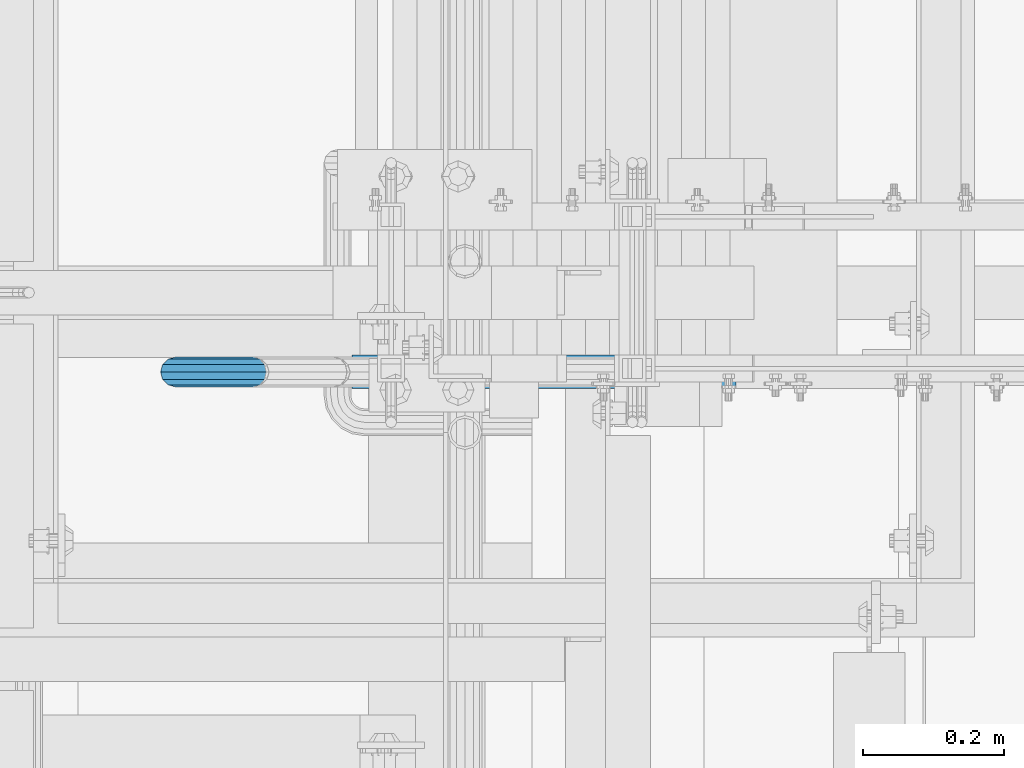
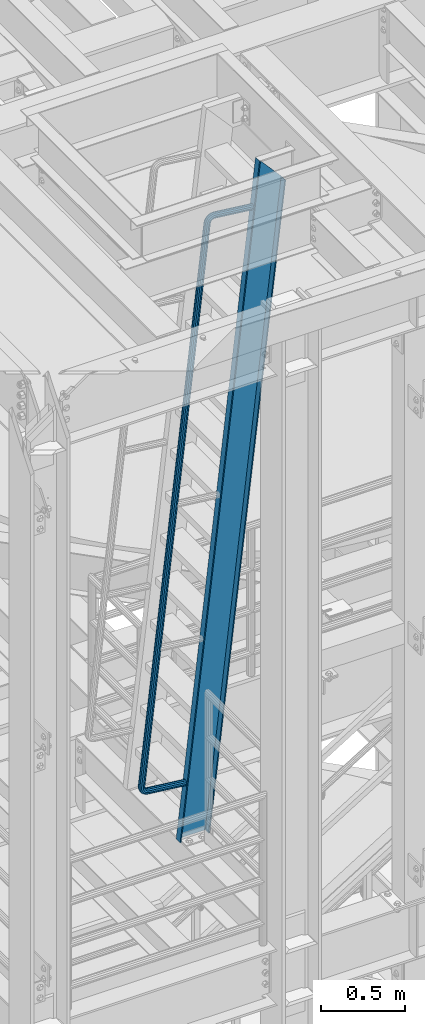
# One storey, part 936 of 1876: 1 beam, 1 member, 1 element without a shape of its own.
"""IFC2X3 building model written with IfcOpenShell, lengths in millimetres."""

import ifcopenshell
import ifcopenshell.guid

model = None  # the IFC model being written
_history = None  # IfcOwnerHistory: only IFC2X3 demands one
_inside = {}  # id of a spatial element -> (the spatial element, [elements in it])
_under = {}  # id of a project, library or spatial element -> (it, [spatial elements below it])
_declared = {}  # id of a project -> (the project, [libraries it declares])
_typed = {}  # id of a type object -> (the type object, [elements of that type])
_made_of = {}  # id of a material, layer set ... -> (it, [elements and type objects made of it])


def new_model(schema):
    """Start an empty IFC model of exactly this schema.

    Asked for "IFC4X3", IfcOpenShell would pick the latest addendum, in which some entities
    have other attributes; the version numbers below select the first issue.
    IFC2X3 requires an IfcOwnerHistory on every rooted entity: one is made here for all.
    """
    global model, _history
    if schema == "IFC4X3":
        model = ifcopenshell.file(schema_version=(4, 3, 0, 0))
    else:
        model = ifcopenshell.file(schema=schema)
    _inside.clear()
    _under.clear()
    _declared.clear()
    _typed.clear()
    _made_of.clear()
    _history = None
    if model.schema == "IFC2X3":
        org = make("IfcOrganization", Name="unknown")
        user = make(
            "IfcPersonAndOrganization",
            ThePerson=make("IfcPerson", FamilyName="unknown"),
            TheOrganization=org,
        )
        app = make(
            "IfcApplication",
            ApplicationDeveloper=org,
            Version="unknown",
            ApplicationFullName="unknown",
            ApplicationIdentifier="unknown",
        )
        _history = make(
            "IfcOwnerHistory",
            OwningUser=user,
            OwningApplication=app,
            ChangeAction="ADDED",
            CreationDate=0,
        )
    return model


def make(cls, **values):
    """One entity of the class cls with the attributes given. An attribute that is None is left unset."""
    return model.create_entity(
        cls, **{name: value for name, value in values.items() if value is not None}
    )


def rooted(cls, **values):
    """An entity with a GlobalId (a new one), such as an element, a storey or a relation."""
    return make(cls, GlobalId=ifcopenshell.guid.new(), OwnerHistory=_history, **values)


def si_unit(unit_type, name, prefix=None):
    """IfcSIUnit, for example si_unit("LENGTHUNIT", "METRE", prefix="MILLI")."""
    return make("IfcSIUnit", UnitType=unit_type, Prefix=prefix, Name=name)


def assignment(units):
    """IfcUnitAssignment: the units of a project."""
    return None if units is None else make("IfcUnitAssignment", Units=units)


def point(xyz):
    """IfcCartesianPoint."""
    return None if xyz is None else make("IfcCartesianPoint", Coordinates=xyz)


def direction(xyz):
    """IfcDirection."""
    return None if xyz is None else make("IfcDirection", DirectionRatios=xyz)


def frame(location, z_axis=None, x_axis=None):
    """IfcAxis2Placement3D, a coordinate frame: its origin and axes. An axis left out is left unset."""
    return make(
        "IfcAxis2Placement3D",
        Location=point(location),
        Axis=direction(z_axis),
        RefDirection=direction(x_axis),
    )


def origin_with_axes():
    """The frame at (0, 0, 0) with the z axis (0, 0, 1) and the x axis (1, 0, 0) written out."""
    return frame((0.0, 0.0, 0.0), z_axis=(0.0, 0.0, 1.0), x_axis=(1.0, 0.0, 0.0))


def place(relative_to, where):
    """IfcLocalPlacement: puts the frame where relative to a parent placement (None: the world)."""
    return make(
        "IfcLocalPlacement", PlacementRelTo=relative_to, RelativePlacement=where
    )


def context(
    kind, dimensions, precision=None, world=None, true_north=None, identifier=None
):
    """IfcGeometricRepresentationContext, for example the 3D "Model" context."""
    return make(
        "IfcGeometricRepresentationContext",
        ContextIdentifier=identifier,
        ContextType=kind,
        CoordinateSpaceDimension=dimensions,
        Precision=precision,
        WorldCoordinateSystem=world,
        TrueNorth=true_north,
    )


def subcontext(parent, identifier, kind, view, scale=None):
    """IfcGeometricRepresentationSubContext, for example "Body" below "Model"."""
    return make(
        "IfcGeometricRepresentationSubContext",
        ContextIdentifier=identifier,
        ContextType=kind,
        ParentContext=parent,
        TargetScale=scale,
        TargetView=view,
    )


def project(units=None, contexts=None):
    """IfcProject with its units and contexts."""
    return rooted(
        "IfcProject",
        Name="project",
        RepresentationContexts=contexts,
        UnitsInContext=assignment(units),
    )


def spatial(cls, under=None, at=None, **own):
    """A site, building, storey or space (cls), placed at a placement, below another one or the project."""
    s = rooted(cls, ObjectPlacement=at, **own)
    if under is not None:
        _under.setdefault(under.id(), (under, []))[1].append(s)
    return s


def faces_of(points, faces, orient=None, outer=None):
    """IfcFace entities. A face is a list of loops; a loop is a list of indices into points, from 0.

    orient and outer hold one flag for each loop. By default every Orientation is true, the
    first loop of a face is its IfcFaceOuterBound and the others are IfcFaceBound.
    """
    made = []
    for i, loops in enumerate(faces):
        bounds = []
        for j, loop in enumerate(loops):
            is_outer = j == 0 if outer is None else outer[i][j]
            bounds.append(
                make(
                    "IfcFaceOuterBound" if is_outer else "IfcFaceBound",
                    Bound=make("IfcPolyLoop", Polygon=[points[k] for k in loop]),
                    Orientation=True if orient is None else orient[i][j],
                )
            )
        made.append(make("IfcFace", Bounds=bounds))
    return made


def faceted_brep(points, faces, orient=None, outer=None, voids=None):
    """IfcFacetedBrep: a solid bounded by flat faces; with voids (closed shells), ...WithVoids."""
    shared = [point(p) for p in points]
    hull = make("IfcClosedShell", CfsFaces=faces_of(shared, faces, orient, outer))
    if voids is None:
        return make("IfcFacetedBrep", Outer=hull)
    return make(
        "IfcFacetedBrepWithVoids",
        Outer=hull,
        Voids=[
            make(cls, CfsFaces=faces_of(shared, fs, o, b)) for cls, fs, o, b in voids
        ],
    )


def shape(context_of_items, identifier, shape_type, items):
    """IfcShapeRepresentation: the items that make up one representation, for example the "Body"."""
    return make(
        "IfcShapeRepresentation",
        ContextOfItems=context_of_items,
        RepresentationIdentifier=identifier,
        RepresentationType=shape_type,
        Items=items,
    )


def material(Name=None, Category=None):
    """IfcMaterial."""
    return make("IfcMaterial", Name=Name, Category=Category)


def made_of(thing, what):
    """Note that an element or type object is made of a material, layer set ...; save() writes the relation."""
    if what is not None:
        _made_of.setdefault(what.id(), (what, []))[1].append(thing)
    return thing


def type_object(cls, material=None, **own):
    """A type object (cls), such as IfcWallType, which elements share."""
    return made_of(rooted(cls, **own), material)


def element(
    cls,
    number,
    at=None,
    inside=None,
    cuts=None,
    type_object=None,
    material=None,
    context=None,
    identifier="Body",
    shape_type=None,
    held_by="IfcProductDefinitionShape",
    body=None,
    shapes=None,
    **own,
):
    """One element of the class cls, such as IfcWall. Its Tag is "e" and its number.

    at: its placement. inside: the storey or other place that contains it. cuts: it is an
    opening in that element (IfcRelVoidsElement). A single representation is given by context,
    identifier, shape_type and body (its items); several are given by shapes. held_by: the class
    of the entity that holds the representations. save() writes the other relations.
    """
    e = rooted(cls, Tag="e%d" % number, ObjectPlacement=at, **own)
    if body is not None:
        shapes = [shape(context, identifier, shape_type, body)]
    if shapes is not None:
        e.Representation = make(held_by, Representations=shapes)
    if inside is not None:
        _inside.setdefault(inside.id(), (inside, []))[1].append(e)
    if cuts is not None:
        rooted(
            "IfcRelVoidsElement", RelatingBuildingElement=cuts, RelatedOpeningElement=e
        )
    if type_object is not None:
        _typed.setdefault(type_object.id(), (type_object, []))[1].append(e)
    return made_of(e, material)


def aggregate(whole, parts):
    """IfcRelAggregates: a whole, such as a stair, and the parts it consists of."""
    return rooted("IfcRelAggregates", RelatingObject=whole, RelatedObjects=parts)


def save(model, path):
    """Write the relations noted so far, then the file.

    IfcRelAggregates (storeys below a building ...), IfcRelContainedInSpatialStructure (elements
    in a storey), IfcRelDefinesByType, IfcRelAssociatesMaterial and IfcRelDeclares: one each for
    every whole, place, type object, material and project.
    """
    for whole, parts in _under.values():
        aggregate(whole, parts)
    for where, things in _inside.values():
        rooted(
            "IfcRelContainedInSpatialStructure",
            RelatedElements=things,
            RelatingStructure=where,
        )
    for kind, things in _typed.values():
        rooted("IfcRelDefinesByType", RelatedObjects=things, RelatingType=kind)
    for what, things in _made_of.values():
        rooted("IfcRelAssociatesMaterial", RelatedObjects=things, RelatingMaterial=what)
    for by, libraries in _declared.values():
        rooted("IfcRelDeclares", RelatingContext=by, RelatedDefinitions=libraries)
    model.write(path)


model = new_model("IFC2X3")

# Units and contexts
model_context = context("Model", 3, precision=1e-05, world=origin_with_axes())
body_context = subcontext(model_context, "Body", "Model", "MODEL_VIEW")
ifc_project = project(units=[si_unit("LENGTHUNIT", "METRE", prefix="MILLI"), si_unit("AREAUNIT", "SQUARE_METRE"), si_unit("VOLUMEUNIT", "CUBIC_METRE"), si_unit("MASSUNIT", "GRAM", prefix="KILO"), si_unit("TIMEUNIT", "SECOND"), si_unit("PLANEANGLEUNIT", "RADIAN"), si_unit("SOLIDANGLEUNIT", "STERADIAN"), si_unit("THERMODYNAMICTEMPERATUREUNIT", "DEGREE_CELSIUS"), si_unit("LUMINOUSINTENSITYUNIT", "LUMEN")], contexts=[model_context])

# Site, building, storey
site_placement = place(None, origin_with_axes())
site = spatial("IfcSite", under=ifc_project, at=site_placement, CompositionType="ELEMENT")
building_placement = place(site_placement, origin_with_axes())
building = spatial("IfcBuilding", under=site, at=building_placement, Name="Undefined", CompositionType="ELEMENT")
storey_placement = place(building_placement, origin_with_axes())
storey = spatial("IfcBuildingStorey", under=building, at=storey_placement, Name="Undefined", CompositionType="ELEMENT", Elevation=0.0)

# Assembly, beam, member
assembly_placement = place(storey_placement, origin_with_axes())
assembly = element("IfcElementAssembly", 1, at=assembly_placement, inside=storey, Name="RIGHT STRINGER", AssemblyPlace="NOTDEFINED", PredefinedType="RIGID_FRAME")
ifc_material_1 = material()
beam_type = type_object("IfcBeamType", Name="PIPE1-1/4SCH40", PredefinedType="NOTDEFINED")
beam_placement = place(assembly_placement, frame((1667.63601242518, -5954.7125, 18406.9079301203), z_axis=(0.113813257034502, 0.0, 0.993502160301224), x_axis=(-0.993502248055299, 0.0, 0.113812491006334)))
beam = element("IfcBeam", 2, at=beam_placement, type_object=beam_type, material=ifc_material_1, Name="RAIL", ObjectType="PIPE1-1/4SCH40", context=body_context, shape_type="Brep", body=[
    faceted_brep([(9.09494701772928e-13, -21.0820000000003, 0.0), (0.0, -18.2575475625836, -10.5409999999993), (260.35000263722, -18.2575475625836, -10.5410004914556), (260.350002657111, -21.0820000000003, -4.91440005134791e-07), (0.0, -10.5410000000002, -18.2575475625836), (260.350002622659, -10.5410000000002, -18.2575480540509), (-4.28826751885936e-09, 0.0, -21.0820000000003), (260.350002617329, 0.0, -21.0820004914713), (0.0, 10.5410000000002, -18.2575475625836), (260.350002622659, 10.5410000000002, -18.2575480540509), (0.0, 18.2575475625836, -10.5409999999993), (260.35000263722, 18.2575475625836, -10.5410004914556), (9.09494701772928e-13, 21.0820000000003, 0.0), (260.350002657111, 21.0820000000003, -4.91440005134791e-07), (0.0, 18.2575475625836, 10.5409999999993), (260.350002677003, 18.2575475625836, 10.5409995085683), (0.0, 10.5410000000002, 18.2575475625836), (260.350002691564, 10.5410000000002, 18.2575470711672), (0.0, 0.0, 21.0820000000003), (260.350002696894, 0.0, 21.0819995085876), (0.0, -10.5410000000002, 18.2575475625836), (260.350002691564, -10.5410000000002, 18.2575470711672), (0.0, -18.2575475625836, 10.5409999999993), (260.350002677003, -18.2575475625836, 10.5409995085683), (0.0, -17.5259999999998, 0.0), (0.0, -15.1779612267264, 8.76300000000083), (260.350002673647, -15.1779612267264, 8.76299950856628), (260.350002657111, -17.5259999999998, -4.91440005134791e-07), (0.0, -8.76299999999992, 15.1779612267255), (260.350002685753, -8.76299999999992, 15.1779607353055), (0.0, 0.0, 17.5259999999998), (260.350002690184, 0.0, 17.5259995085835), (0.0, 8.76299999999992, 15.1779612267255), (260.350002685753, 8.76299999999992, 15.1779607353055), (0.0, 15.1779612267264, 8.76300000000083), (260.350002673647, 15.1779612267264, 8.76299950856628), (0.0, 17.5259999999998, 0.0), (260.350002657111, 17.5259999999998, -4.91440005134791e-07), (0.0, 15.1779612267264, -8.76300000000083), (260.350002640575, 15.1779612267264, -8.76300049145357), (0.0, 8.76299999999992, -15.1779612267255), (260.35000262847, 8.76299999999992, -15.1779617181928), (0.0, 0.0, -17.5259999999998), (260.350002624039, 0.0, -17.5260004914671), (0.0, -8.76299999999992, -15.1779612267255), (260.35000262847, -8.76299999999992, -15.1779617181928), (0.0, -15.1779612267264, -8.76300000000083), (260.350002640575, -15.1779612267264, -8.76300049145357), (274.08580829423, -21.0820000000003, 2.17553736977061), (270.828460176085, -18.2575475625836, 12.2006241144154), (268.443915855663, -10.5410000000002, 19.5394969617737), (267.57111205794, 0.0, 22.2257108590529), (268.443915855663, 10.5410000000002, 19.5394969617737), (270.828460176085, 18.2575475625836, 12.2006241144154), (274.08580829423, 21.0820000000003, 2.17553736977061), (277.343156412376, 18.2575475625836, -7.84954937486691), (279.727700732797, 10.5410000000002, -15.1884222222252), (280.600504530522, 0.0, -17.8746361195081), (279.727700732797, -10.5410000000002, -15.1884222222252), (277.343156412376, -18.2575475625836, -7.84954937486691), (279.501640105123, 0.0, -14.4926791454127), (278.776056225087, 8.76299999999992, -12.2595615681566), (276.793724199676, 15.1779612267264, -6.15857088781922), (274.08580829423, 17.5259999999998, 2.17553736977061), (271.377892388784, 15.1779612267264, 10.5096456273677), (269.395560363374, 8.76299999999992, 16.6106363077015), (268.669976483338, 0.0, 18.8437538849576), (269.395560363374, -8.76299999999992, 16.6106363077015), (271.377892388784, -15.1779612267264, 10.5096456273677), (274.08580829423, -17.5259999999998, 2.17553736977061), (276.793724199676, -15.1779612267264, -6.15857088781922), (278.776056225087, -8.76299999999992, -12.2595615681566), (292.672901908588, 18.2575475625836, -0.0386539485734829), (297.208574751905, 10.5410000000002, -6.28147207375514), (286.477057581359, 21.0820000000003, 8.4891942016402), (280.281213254131, 18.2575475625836, 17.0170423518503), (275.745540410813, 10.5410000000002, 23.2598604770355), (274.085368926903, 0.0, 25.544890502053), (275.745540410813, -10.5410000000002, 23.2598604770355), (280.281213254131, -18.2575475625836, 17.0170423518503), (286.477057581359, -21.0820000000003, 8.4891942016402), (292.672901908588, -18.2575475625836, -0.0386539485734829), (297.208574751905, -10.5410000000002, -6.28147207375514), (298.868746235816, 0.0, -8.56650209877625), (295.398439325548, -8.76299999999992, -3.79003438874497), (296.778581884461, 0.0, -5.68963766256275), (291.62781973291, -15.1779612267264, 1.39977826953327), (286.477057581359, -17.5259999999998, 8.4891942016402), (281.326295429808, -15.1779612267264, 15.5786101337435), (277.55567583717, -8.76299999999992, 20.768422792029), (276.175533278257, 0.0, 22.6680260658432), (277.55567583717, 8.76299999999992, 20.768422792029), (281.326295429808, 15.1779612267264, 15.5786101337435), (286.477057581359, 17.5259999999998, 8.4891942016402), (291.62781973291, 15.1779612267264, 1.39977826953327), (295.398439325548, 8.76299999999992, -3.79003438874497), (304.838656828675, 18.2575475625836, 12.1271009217089), (311.081474935276, 10.5410000000002, 7.5914280528159), (296.310808703854, 21.0820000000003, 18.322945283875), (287.782960579032, 18.2575475625836, 24.5187896460338), (281.540142472431, 10.5410000000002, 29.0544625149305), (279.25511245421, 0.0, 30.7146340081999), (281.540142472431, -10.5410000000002, 29.0544625149305), (287.782960579032, -18.2575475625836, 24.5187896460338), (296.310808703854, -21.0820000000003, 18.322945283875), (304.838656828675, -18.2575475625836, 12.1271009217089), (311.081474935276, -10.5410000000002, 7.5914280528159), (313.366504953497, 0.0, 5.93125655954645), (308.590037257687, -8.76299999999992, 9.40156348937671), (310.489640525846, 0.0, 8.02142092268332), (303.40022461485, -15.1779612267264, 13.172183103281), (296.310808703854, -17.5259999999998, 18.322945283875), (289.221392792858, -15.1779612267264, 23.4737074644654), (284.031580150021, -8.76299999999992, 27.2443270783624), (282.131976881861, 0.0, 28.6244696450594), (284.031580150021, 8.76299999999992, 27.2443270783624), (289.221392792858, 15.1779612267264, 23.4737074644654), (296.310808703854, 17.5259999999998, 18.322945283875), (303.40022461485, 15.1779612267264, 13.172183103281), (308.590037257687, 8.76299999999992, 9.40156348937671), (312.649552317749, 18.2575475625836, 27.4568463859578), (319.988425155334, 10.5410000000002, 25.0723020354744), (302.624465586464, 21.0820000000003, 30.7141945451658), (292.599378855178, 18.2575475625836, 33.9715427043739), (285.260506017593, 10.5410000000002, 36.3560870548536), (282.574292123894, 0.0, 37.2288908635783), (285.260506017593, -10.5410000000002, 36.3560870548536), (292.599378855178, -18.2575475625836, 33.9715427043739), (302.624465586464, -21.0820000000003, 30.7141945451658), (312.649552317749, -18.2575475625836, 27.4568463859578), (319.988425155334, -10.5410000000002, 25.0723020354744), (322.674639049034, 0.0, 24.1994982267497), (317.059564505163, -8.76299999999992, 26.0239465551822), (319.292682079444, 0.0, 25.2983626659989), (310.958573832954, -15.1779612267264, 28.0062786055823), (302.624465586464, -17.5259999999998, 30.7141945451658), (294.290357339974, -15.1779612267264, 33.4221104847456), (288.189366667764, -8.76299999999992, 35.4044425351494), (285.956249093484, 0.0, 36.1300264243291), (288.189366667764, 8.76299999999992, 35.4044425351494), (294.290357339974, 15.1779612267264, 33.4221104847456), (302.624465586464, 17.5259999999998, 30.7141945451658), (310.958573832954, 15.1779612267264, 28.0062786055823), (317.059564505163, 8.76299999999992, 26.0239465551822), (323.057551066515, -10.5410000000002, 44.4500001330634), (315.341003503932, -18.2575475625836, 44.4500001501037), (325.882003503932, 0.0, 44.4500001268316), (323.057551066515, 10.5410000000002, 44.4500001330634), (315.341003503932, 18.2575475625836, 44.4500001501037), (304.80000350393, 21.0820000000003, 44.4500001733868), (294.25900350393, 18.2575475625836, 44.4500001966699), (286.542455941346, 10.5410000000002, 44.4500002137138), (283.718003503929, 0.0, 44.4500002199493), (286.542455941346, -10.5410000000002, 44.4500002137138), (294.25900350393, -18.2575475625836, 44.4500001966699), (304.800003503935, -21.0820000000003, 44.4500001733904), (319.977964730658, -8.76299999999992, 44.4500001398665), (322.326003503932, 0.0, 44.4500001346823), (313.563003503931, -15.1779612267264, 44.4500001540328), (304.800003503935, -17.5259999999998, 44.4500001733904), (296.03700350393, -15.1779612267264, 44.4500001927445), (289.622042277204, -8.76299999999992, 44.4500002069108), (287.27400350393, 0.0, 44.4500002120949), (289.622042277204, 8.76299999999992, 44.4500002069108), (296.03700350393, 15.1779612267264, 44.4500001927445), (304.80000350393, 17.5259999999998, 44.4500001733868), (313.563003503931, 15.1779612267264, 44.4500001540328), (319.977964730658, 8.76299999999992, 44.4500001398665), (315.341042452032, -18.2575475625836, 4001.85800783008), (304.800042452033, -21.0820000000003, 4001.85800794304), (323.057590014616, -10.5410000000002, 4001.85800774739), (325.882042452032, 0.0, 4001.85800771712), (323.057590014616, 10.5410000000002, 4001.85800774739), (315.341042452032, 18.2575475625836, 4001.85800783008), (304.800042452033, 21.0820000000003, 4001.85800794304), (294.259042452034, 18.2575475625836, 4001.858008056), (286.542494889451, 10.5410000000002, 4001.85800813869), (283.718042452035, 0.0, 4001.85800816896), (286.542494889451, -10.5410000000002, 4001.85800813869), (294.259042452034, -18.2575475625836, 4001.858008056), (296.037042452034, -15.1779612267264, 4001.85800803694), (304.800042452033, -17.5259999999998, 4001.85800794304), (289.622081225308, -8.76299999999992, 4001.85800810569), (287.274042452034, 0.0, 4001.85800813085), (289.622081225308, 8.76299999999992, 4001.85800810569), (296.037042452034, 15.1779612267264, 4001.85800803694), (304.800042452033, 17.5259999999998, 4001.85800794304), (313.563042452033, 15.1779612267264, 4001.85800784914), (319.978003678758, 8.76299999999992, 4001.8580077804), (322.326042452032, 0.0, 4001.85800775523), (319.978003678758, -8.76299999999992, 4001.8580077804), (313.563042452033, -15.1779612267264, 4001.85800784914), (302.624503394555, -21.0820000000003, 4015.5938176543), (292.599416933616, -18.2575475625836, 4012.33646866306), (285.260544293939, -10.5410000000002, 4009.9519237035), (282.574330472678, 0.0, 4009.07911967183), (285.260544293939, 10.5410000000002, 4009.9519237035), (292.599416933616, 18.2575475625836, 4012.33646866306), (302.624503394555, 21.0820000000003, 4015.5938176543), (312.649589855493, 18.2575475625836, 4018.85116664553), (319.988462495171, 10.5410000000002, 4021.2357116051), (322.674676316432, 0.0, 4022.10851563676), (319.988462495171, -10.5410000000002, 4021.2357116051), (312.649589855493, -18.2575475625836, 4018.85116664553), (319.292719438043, 0.0, 4021.00965091683), (317.059601923983, 8.76299999999992, 4020.28406684231), (310.958611416299, 15.1779612267264, 4018.30173428556), (302.624503394555, 17.5259999999998, 4015.5938176543), (294.290395372811, 15.1779612267264, 4012.88590102303), (288.189404865127, 8.76299999999992, 4010.90356846628), (285.956287351067, 0.0, 4010.17798439176), (288.189404865127, -8.76299999999992, 4010.90356846628), (294.290395372811, -15.1779612267264, 4012.88590102303), (302.624503394555, -17.5259999999998, 4015.5938176543), (310.958611416299, -15.1779612267264, 4018.30173428556), (317.059601923983, -8.76299999999992, 4020.28406684231), (304.838689993735, 18.2575475625836, 4034.18091572881), (311.081507288835, 10.5410000000002, 4038.71658971462), (296.310842977442, 21.0820000000003, 4027.9850698409), (287.782995961149, 18.2575475625836, 4021.78922395299), (281.540178666048, 10.5410000000002, 4017.25354996718), (279.255148944857, 0.0, 4015.59337806508), (281.540178666048, -10.5410000000002, 4017.25354996718), (287.782995961149, -18.2575475625836, 4021.78922395299), (296.310842977442, -21.0820000000003, 4027.9850698409), (304.838689993735, -18.2575475625836, 4034.18091572881), (311.081507288835, -10.5410000000002, 4038.71658971462), (313.366537010027, 0.0, 4040.37676161671), (308.590069935106, -8.76299999999992, 4036.9064538323), (310.489672956338, 0.0, 4038.28659673886), (303.40025796689, -15.1779612267264, 4033.13583328989), (296.310842977442, -17.5259999999998, 4027.9850698409), (289.221427987993, -15.1779612267264, 4022.83430639191), (284.031616019777, -8.76299999999992, 4019.06368584949), (282.132012998545, 0.0, 4017.68354294293), (284.031616019777, 8.76299999999992, 4019.06368584949), (289.221427987993, 15.1779612267264, 4022.83430639191), (296.310842977442, 17.5259999999998, 4027.9850698409), (303.40025796689, 15.1779612267264, 4033.13583328989), (308.590069935107, 8.76299999999992, 4036.90645383231), (292.672928629694, 18.2575475625836, 4046.34667152283), (297.208599757273, 10.5410000000002, 4052.58949089456), (286.477086646212, 21.0820000000003, 4037.81882166981), (280.281244662728, 18.2575475625836, 4029.29097181679), (275.74557353515, 10.5410000000002, 4023.04815244505), (274.085402679244, 0.0, 4020.76312196376), (275.74557353515, -10.5410000000002, 4023.04815244505), (280.281244662728, -18.2575475625836, 4029.29097181679), (286.477086646212, -21.0820000000003, 4037.81882166981), (292.672928629694, -18.2575475625836, 4046.34667152283), (297.208599757273, -10.5410000000002, 4052.58949089456), (298.868770613178, 0.0, 4054.87452137585), (295.398465015647, -8.76299999999992, 4050.09805271207), (296.778607052484, 0.0, 4051.99765636519), (291.627846849348, -15.1779612267264, 4044.9082390175), (286.477086646212, -17.5259999999998, 4037.81882166981), (281.326326443074, -15.1779612267264, 4030.72940432212), (277.555708276775, -8.76299999999992, 4025.53959062754), (276.175566239938, 0.0, 4023.63998697442), (277.555708276775, 8.76299999999992, 4025.53959062754), (281.326326443074, 15.1779612267264, 4030.72940432212), (286.477086646212, 17.5259999999998, 4037.81882166981), (291.627846849348, 15.1779612267264, 4044.9082390175), (295.398465015648, 8.76299999999992, 4050.09805271207), (277.343175970252, 18.2575475625836, 4054.15756436596), (279.727717569761, 10.5410000000002, 4061.49643809739), (274.085831568942, 21.0820000000003, 4044.13247641366), (270.828487167633, 18.2575475625836, 4034.10738846137), (268.443945568125, 10.5410000000002, 4026.76851472994), (267.571142766324, 0.0, 4024.08230050907), (268.443945568125, -10.5410000000002, 4026.76851472994), (270.828487167633, -18.2575475625836, 4034.10738846137), (274.085831568942, -21.0820000000003, 4044.13247641366), (277.343175970252, -18.2575475625836, 4054.15756436596), (279.727717569761, -10.5410000000002, 4061.49643809739), (280.600520371562, 0.0, 4064.18265231825), (278.776074147935, -8.76299999999992, 4058.56757709049), (279.501657200035, 0.0, 4060.80069493676), (276.793744384489, -15.1779612267264, 4052.46658567521), (274.085831568942, -17.5259999999998, 4044.13247641366), (271.377918753396, -15.1779612267264, 4035.79836715211), (269.39558898995, -8.76299999999992, 4029.69737573683), (268.67000593785, 0.0, 4027.46425789056), (269.39558898995, 8.76299999999992, 4029.69737573683), (271.377918753396, 15.1779612267264, 4035.79836715211), (274.085831568942, 17.5259999999998, 4044.13247641366), (276.793744384489, 15.1779612267264, 4052.46658567521), (278.776074147935, 8.76299999999992, 4058.56757709049), (260.35001230687, -10.5410000000002, 4064.56555674487), (260.350015922533, -18.2575475625836, 4056.84900918229), (260.350010983444, 0.0, 4067.39000918229), (260.35001230687, 10.5410000000002, 4064.56555674487), (260.350015922533, 18.2575475625836, 4056.84900918229), (260.350020861621, 21.0820000000003, 4046.30800918228), (260.35002580071, 18.2575475625836, 4035.76700918229), (260.350029416376, 10.5410000000002, 4028.0504616197), (260.350030739801, 0.0, 4025.22600918229), (260.350029416376, -10.5410000000002, 4028.0504616197), (260.35002580071, -18.2575475625836, 4035.76700918229), (260.350020861614, -21.0820000000003, 4046.30800918231), (260.35001374984, -8.76299999999992, 4061.48597040901), (260.350012649643, 0.0, 4063.83400918228), (260.350016755632, -15.1779612267264, 4055.07100918229), (260.350020861614, -17.5259999999998, 4046.30800918231), (260.350024967611, -15.1779612267264, 4037.54500918229), (260.350027973405, -8.76299999999992, 4031.13004795556), (260.350029073602, 0.0, 4028.78200918228), (260.350027973405, 8.76299999999992, 4031.13004795556), (260.350024967611, 15.1779612267264, 4037.54500918229), (260.350020861621, 17.5259999999998, 4046.30800918228), (260.350016755632, 15.1779612267264, 4055.07100918229), (260.35001374984, 8.76299999999992, 4061.48597040901), (-2.39923139702114e-05, -18.2575475625836, 4056.84888719286), (-1.90532256851839e-05, -21.0820000000003, 4046.30788719285), (-2.76079783247951e-05, -10.5410000000002, 4064.56543475544), (-2.89314031647336e-05, 0.0, 4067.38988719286), (-2.76079783247951e-05, 10.5410000000002, 4064.56543475544), (-2.39923139702114e-05, 18.2575475625836, 4056.84888719286), (-1.90532256851839e-05, 21.0820000000003, 4046.30788719285), (-1.4114136945409e-05, 18.2575475625836, 4035.76688719285), (-1.04984725908253e-05, 10.5410000000002, 4028.05033963027), (-9.17504775088673e-06, 0.0, 4025.22588719285), (-1.04984725908253e-05, -10.5410000000002, 4028.05033963027), (-1.4114136945409e-05, -18.2575475625836, 4035.76688719285), (-1.4947235456475e-05, -15.1779612267264, 4037.54488719285), (-1.90532256851839e-05, -17.5259999999998, 4046.30788719285), (-1.19414427786069e-05, -8.76299999999992, 4031.12992596612), (-1.08412465920082e-05, 0.0, 4028.78188719285), (-1.19414427786069e-05, 8.76299999999992, 4031.12992596612), (-1.4947235456475e-05, 15.1779612267264, 4037.54488719285), (-1.90532256851839e-05, 17.5259999999998, 4046.30788719285), (-2.3159215004398e-05, 15.1779612267264, 4055.07088719286), (-2.61650076822662e-05, 8.76299999999992, 4061.48584841958), (-2.72652047783595e-05, 0.0, 4063.83388719286), (-2.61650076822662e-05, -8.76299999999992, 4061.48584841958), (-2.3159215004398e-05, -15.1779612267264, 4055.07088719286)], [[[0, 1, 2, 3]], [[1, 4, 5, 2]], [[4, 6, 7, 5]], [[6, 8, 9, 7]], [[8, 10, 11, 9]], [[10, 12, 13, 11]], [[12, 14, 15, 13]], [[14, 16, 17, 15]], [[16, 18, 19, 17]], [[18, 20, 21, 19]], [[20, 22, 23, 21]], [[22, 0, 3, 23]], [[24, 25, 26, 27]], [[25, 28, 29, 26]], [[28, 30, 31, 29]], [[30, 32, 33, 31]], [[32, 34, 35, 33]], [[34, 36, 37, 35]], [[36, 38, 39, 37]], [[38, 40, 41, 39]], [[40, 42, 43, 41]], [[42, 44, 45, 43]], [[44, 46, 47, 45]], [[46, 24, 27, 47]], [[22, 20, 18, 16, 14, 12, 10, 8, 6, 4, 1, 0], [46, 44, 42, 40, 38, 36, 34, 32, 30, 28, 25, 24]], [[23, 3, 48, 49]], [[21, 23, 49, 50]], [[19, 21, 50, 51]], [[17, 19, 51, 52]], [[15, 17, 52, 53]], [[13, 15, 53, 54]], [[11, 13, 54, 55]], [[9, 11, 55, 56]], [[7, 9, 56, 57]], [[5, 7, 57, 58]], [[2, 5, 58, 59]], [[3, 2, 59, 48]], [[41, 43, 60, 61]], [[39, 41, 61, 62]], [[37, 39, 62, 63]], [[35, 37, 63, 64]], [[33, 35, 64, 65]], [[31, 33, 65, 66]], [[29, 31, 66, 67]], [[26, 29, 67, 68]], [[27, 26, 68, 69]], [[47, 27, 69, 70]], [[45, 47, 70, 71]], [[43, 45, 71, 60]], [[55, 72, 73, 56]], [[54, 74, 72, 55]], [[53, 75, 74, 54]], [[52, 76, 75, 53]], [[51, 77, 76, 52]], [[50, 78, 77, 51]], [[49, 79, 78, 50]], [[48, 80, 79, 49]], [[59, 81, 80, 48]], [[58, 82, 81, 59]], [[57, 83, 82, 58]], [[56, 73, 83, 57]], [[71, 84, 85, 60]], [[70, 86, 84, 71]], [[69, 87, 86, 70]], [[68, 88, 87, 69]], [[67, 89, 88, 68]], [[66, 90, 89, 67]], [[65, 91, 90, 66]], [[64, 92, 91, 65]], [[63, 93, 92, 64]], [[62, 94, 93, 63]], [[61, 95, 94, 62]], [[60, 85, 95, 61]], [[72, 96, 97, 73]], [[74, 98, 96, 72]], [[75, 99, 98, 74]], [[76, 100, 99, 75]], [[77, 101, 100, 76]], [[78, 102, 101, 77]], [[79, 103, 102, 78]], [[80, 104, 103, 79]], [[81, 105, 104, 80]], [[82, 106, 105, 81]], [[83, 107, 106, 82]], [[73, 97, 107, 83]], [[84, 108, 109, 85]], [[86, 110, 108, 84]], [[87, 111, 110, 86]], [[88, 112, 111, 87]], [[89, 113, 112, 88]], [[90, 114, 113, 89]], [[91, 115, 114, 90]], [[92, 116, 115, 91]], [[93, 117, 116, 92]], [[94, 118, 117, 93]], [[95, 119, 118, 94]], [[85, 109, 119, 95]], [[96, 120, 121, 97]], [[98, 122, 120, 96]], [[99, 123, 122, 98]], [[100, 124, 123, 99]], [[101, 125, 124, 100]], [[102, 126, 125, 101]], [[103, 127, 126, 102]], [[104, 128, 127, 103]], [[105, 129, 128, 104]], [[106, 130, 129, 105]], [[107, 131, 130, 106]], [[97, 121, 131, 107]], [[108, 132, 133, 109]], [[110, 134, 132, 108]], [[111, 135, 134, 110]], [[112, 136, 135, 111]], [[113, 137, 136, 112]], [[114, 138, 137, 113]], [[115, 139, 138, 114]], [[116, 140, 139, 115]], [[117, 141, 140, 116]], [[118, 142, 141, 117]], [[119, 143, 142, 118]], [[109, 133, 143, 119]], [[130, 144, 145, 129]], [[131, 146, 144, 130]], [[121, 147, 146, 131]], [[120, 148, 147, 121]], [[122, 149, 148, 120]], [[123, 150, 149, 122]], [[124, 151, 150, 123]], [[125, 152, 151, 124]], [[126, 153, 152, 125]], [[127, 154, 153, 126]], [[128, 155, 154, 127]], [[129, 145, 155, 128]], [[132, 156, 157, 133]], [[134, 158, 156, 132]], [[135, 159, 158, 134]], [[136, 160, 159, 135]], [[137, 161, 160, 136]], [[138, 162, 161, 137]], [[139, 163, 162, 138]], [[140, 164, 163, 139]], [[141, 165, 164, 140]], [[142, 166, 165, 141]], [[143, 167, 166, 142]], [[133, 157, 167, 143]], [[155, 145, 168, 169]], [[145, 144, 170, 168]], [[144, 146, 171, 170]], [[146, 147, 172, 171]], [[147, 148, 173, 172]], [[148, 149, 174, 173]], [[149, 150, 175, 174]], [[150, 151, 176, 175]], [[151, 152, 177, 176]], [[152, 153, 178, 177]], [[153, 154, 179, 178]], [[154, 155, 169, 179]], [[159, 160, 180, 181]], [[160, 161, 182, 180]], [[161, 162, 183, 182]], [[162, 163, 184, 183]], [[163, 164, 185, 184]], [[164, 165, 186, 185]], [[165, 166, 187, 186]], [[166, 167, 188, 187]], [[167, 157, 189, 188]], [[157, 156, 190, 189]], [[156, 158, 191, 190]], [[158, 159, 181, 191]], [[179, 169, 192, 193]], [[178, 179, 193, 194]], [[177, 178, 194, 195]], [[176, 177, 195, 196]], [[175, 176, 196, 197]], [[174, 175, 197, 198]], [[173, 174, 198, 199]], [[172, 173, 199, 200]], [[171, 172, 200, 201]], [[170, 171, 201, 202]], [[168, 170, 202, 203]], [[169, 168, 203, 192]], [[188, 189, 204, 205]], [[187, 188, 205, 206]], [[186, 187, 206, 207]], [[185, 186, 207, 208]], [[184, 185, 208, 209]], [[183, 184, 209, 210]], [[182, 183, 210, 211]], [[180, 182, 211, 212]], [[181, 180, 212, 213]], [[191, 181, 213, 214]], [[190, 191, 214, 215]], [[189, 190, 215, 204]], [[199, 216, 217, 200]], [[198, 218, 216, 199]], [[197, 219, 218, 198]], [[196, 220, 219, 197]], [[195, 221, 220, 196]], [[194, 222, 221, 195]], [[193, 223, 222, 194]], [[192, 224, 223, 193]], [[203, 225, 224, 192]], [[202, 226, 225, 203]], [[201, 227, 226, 202]], [[200, 217, 227, 201]], [[215, 228, 229, 204]], [[214, 230, 228, 215]], [[213, 231, 230, 214]], [[212, 232, 231, 213]], [[211, 233, 232, 212]], [[210, 234, 233, 211]], [[209, 235, 234, 210]], [[208, 236, 235, 209]], [[207, 237, 236, 208]], [[206, 238, 237, 207]], [[205, 239, 238, 206]], [[204, 229, 239, 205]], [[216, 240, 241, 217]], [[218, 242, 240, 216]], [[219, 243, 242, 218]], [[220, 244, 243, 219]], [[221, 245, 244, 220]], [[222, 246, 245, 221]], [[223, 247, 246, 222]], [[224, 248, 247, 223]], [[225, 249, 248, 224]], [[226, 250, 249, 225]], [[227, 251, 250, 226]], [[217, 241, 251, 227]], [[228, 252, 253, 229]], [[230, 254, 252, 228]], [[231, 255, 254, 230]], [[232, 256, 255, 231]], [[233, 257, 256, 232]], [[234, 258, 257, 233]], [[235, 259, 258, 234]], [[236, 260, 259, 235]], [[237, 261, 260, 236]], [[238, 262, 261, 237]], [[239, 263, 262, 238]], [[229, 253, 263, 239]], [[240, 264, 265, 241]], [[242, 266, 264, 240]], [[243, 267, 266, 242]], [[244, 268, 267, 243]], [[245, 269, 268, 244]], [[246, 270, 269, 245]], [[247, 271, 270, 246]], [[248, 272, 271, 247]], [[249, 273, 272, 248]], [[250, 274, 273, 249]], [[251, 275, 274, 250]], [[241, 265, 275, 251]], [[252, 276, 277, 253]], [[254, 278, 276, 252]], [[255, 279, 278, 254]], [[256, 280, 279, 255]], [[257, 281, 280, 256]], [[258, 282, 281, 257]], [[259, 283, 282, 258]], [[260, 284, 283, 259]], [[261, 285, 284, 260]], [[262, 286, 285, 261]], [[263, 287, 286, 262]], [[253, 277, 287, 263]], [[274, 288, 289, 273]], [[275, 290, 288, 274]], [[265, 291, 290, 275]], [[264, 292, 291, 265]], [[266, 293, 292, 264]], [[267, 294, 293, 266]], [[268, 295, 294, 267]], [[269, 296, 295, 268]], [[270, 297, 296, 269]], [[271, 298, 297, 270]], [[272, 299, 298, 271]], [[273, 289, 299, 272]], [[276, 300, 301, 277]], [[278, 302, 300, 276]], [[279, 303, 302, 278]], [[280, 304, 303, 279]], [[281, 305, 304, 280]], [[282, 306, 305, 281]], [[283, 307, 306, 282]], [[284, 308, 307, 283]], [[285, 309, 308, 284]], [[286, 310, 309, 285]], [[287, 311, 310, 286]], [[277, 301, 311, 287]], [[299, 289, 312, 313]], [[289, 288, 314, 312]], [[288, 290, 315, 314]], [[290, 291, 316, 315]], [[291, 292, 317, 316]], [[292, 293, 318, 317]], [[293, 294, 319, 318]], [[294, 295, 320, 319]], [[295, 296, 321, 320]], [[296, 297, 322, 321]], [[297, 298, 323, 322]], [[298, 299, 313, 323]], [[303, 304, 324, 325]], [[304, 305, 326, 324]], [[305, 306, 327, 326]], [[306, 307, 328, 327]], [[307, 308, 329, 328]], [[308, 309, 330, 329]], [[309, 310, 331, 330]], [[310, 311, 332, 331]], [[311, 301, 333, 332]], [[301, 300, 334, 333]], [[300, 302, 335, 334]], [[302, 303, 325, 335]], [[314, 315, 316, 317, 318, 319, 320, 321, 322, 323, 313, 312], [326, 327, 328, 329, 330, 331, 332, 333, 334, 335, 325, 324]]]),
])
ifc_material_2 = material(Name="STEEL/A36")
member_type = type_object("IfcMemberType", Name="MC8X8.5", PredefinedType="NOTDEFINED")
member_placement = place(assembly_placement, frame((2267.0574520165, -5954.7125, 22746.8366120043), z_axis=(0.993502247476981, 0.0, -0.113812496054638), x_axis=(-0.113812491006334, 0.0, -0.993502248055299)))
member = element("IfcMember", 3, at=member_placement, type_object=member_type, material=ifc_material_2, Name="LADDER", ObjectType="MC8X8.5", context=body_context, shape_type="Brep", body=[
    faceted_brep([(9.9464159575291e-08, 23.8125, -101.599999999999), (181.250957503763, 23.8125, 101.599999999999), (4767.17434958071, 23.8125, 101.600000000687), (4790.45238148009, 23.8125, -101.599999999278), (181.250957503763, -23.8125, 101.599999999999), (4767.17434958071, -23.8125, 101.600000000687), (174.593524876916, -23.8125, 94.1363687500016), (4768.02936260395, -23.8125, 94.136368750688), (173.83269566275, 19.0500000000002, 93.2834049999983), (4768.12707578004, 19.0500000000002, 93.2834050006879), (7.4182619404769, 19.0500000000002, -93.2834049999983), (4789.49965528076, 19.0500000000002, -93.2834049992798), (6.65743272631016, -23.8125, -94.1363687500016), (4789.59736845685, -23.8125, -94.1363687492799), (9.9464159575291e-08, -23.8125, -101.599999999999), (4790.45238148009, -23.8125, -101.599999999278)], [[[0, 1, 2, 3]], [[1, 4, 5, 2]], [[4, 6, 7, 5]], [[6, 8, 9, 7]], [[8, 10, 11, 9]], [[10, 12, 13, 11]], [[12, 14, 15, 13]], [[14, 0, 3, 15]], [[5, 7, 9, 11, 13, 15, 3, 2]], [[14, 12, 10, 8, 6, 4, 1, 0]]]),
])
aggregate(assembly, [beam, member])

save(model, "model.ifc")
